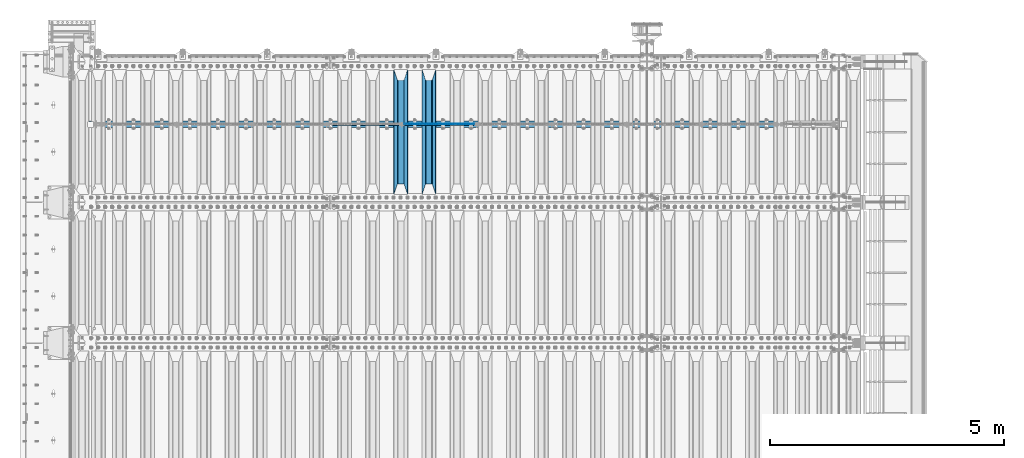
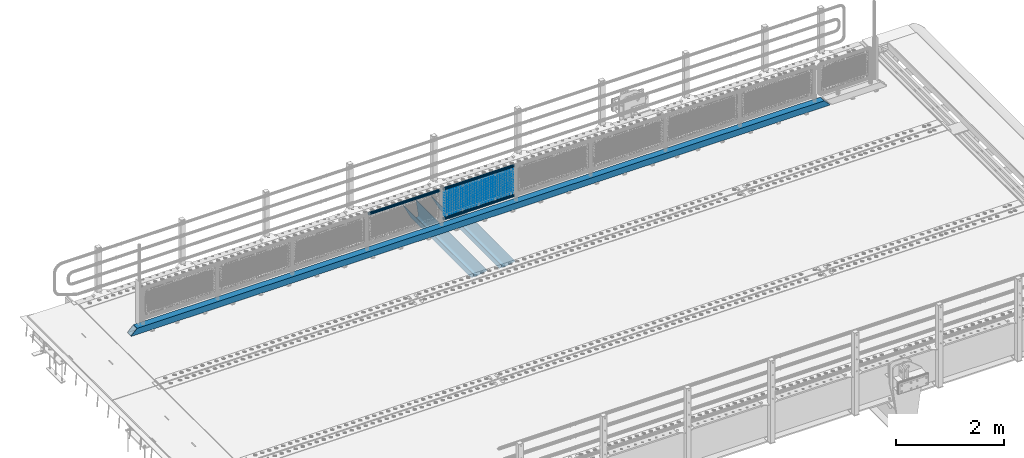
# One storey, part 124 of 247: 23 beams.
"""IFC2X3 building model written with IfcOpenShell, lengths in millimetres."""

from ifc_helpers import new_model, si_unit, frame, origin_with_axes, place, context, subcontext, project, spatial, faceted_brep, material, type_object, element, save


model = new_model("IFC2X3")

# Units and contexts
model_context = context("Model", 3, precision=1e-05, world=origin_with_axes())
body_context = subcontext(model_context, "Body", "Model", "MODEL_VIEW")
ifc_project = project(units=[si_unit("LENGTHUNIT", "METRE", prefix="MILLI"), si_unit("AREAUNIT", "SQUARE_METRE"), si_unit("VOLUMEUNIT", "CUBIC_METRE"), si_unit("MASSUNIT", "GRAM", prefix="KILO"), si_unit("TIMEUNIT", "SECOND"), si_unit("PLANEANGLEUNIT", "RADIAN"), si_unit("SOLIDANGLEUNIT", "STERADIAN"), si_unit("THERMODYNAMICTEMPERATUREUNIT", "DEGREE_CELSIUS"), si_unit("LUMINOUSINTENSITYUNIT", "LUMEN")], contexts=[model_context])

# Site, building, storey
site_placement = place(None, origin_with_axes())
site = spatial("IfcSite", under=ifc_project, at=site_placement, CompositionType="ELEMENT")
building_placement = place(site_placement, origin_with_axes())
building = spatial("IfcBuilding", under=site, at=building_placement, Name="Standard", CompositionType="ELEMENT")
storey_placement = place(building_placement, origin_with_axes())
storey = spatial("IfcBuildingStorey", under=building, at=storey_placement, Name="Undefined", CompositionType="ELEMENT", Elevation=0.0)

# Beams
ifc_material_1 = material(Name="STEEL/S355N")
beam_type_1 = type_object("IfcBeamType", PredefinedType="NOTDEFINED")
beam_1_placement = place(storey_placement, frame((7600.0, 6175.0, -115.0), z_axis=(0.0, 0.0, 1.0), x_axis=(0.0, 1.0, 0.0)))
element("IfcBeam", 1, at=beam_1_placement, inside=storey, type_object=beam_type_1, material=ifc_material_1, context=body_context, shape_type="Brep", body=[
    faceted_brep([(0.0, 150.0, 115.0), (0.0, 143.689999999999, 115.0), (2650.00000000297, 143.689999999999, 115.0), (2650.00000000297, 150.0, 115.0), (2650.00000000297, 142.059565218402, 110.0000000031), (2650.00000000297, 148.369565218403, 110.0000000031), (2441.90079219208, -80.1103600731112, -98.0992078077845), (2437.7588105432, -77.5672621345584, -102.241189456673), (2434.06523489746, -74.4080125315522, -105.934765102404), (2430.91086095089, -70.710272125576, -109.089139048974), (2428.37322971128, -66.5649389910068, -111.626770288588), (2426.51472138054, -62.0739139532889, -113.485278619323), (2425.38102192091, -57.3475956567672, -114.618978078955), (2424.99999999987, -52.5021667386536, -115.0), (2424.99999999987, 52.5021667386536, -115.0), (2425.38102192091, 57.3475956567672, -114.618978078955), (2426.51472138054, 62.0739139532889, -113.485278619323), (2428.37322971128, 66.5649389910068, -111.626770288588), (2430.91086095089, 70.710272125576, -109.089139048974), (2434.06523489746, 74.4080125315522, -105.934765102404), (2437.7588105432, 77.5672621345584, -102.241189456673), (2441.90079219208, 80.1103600731112, -98.0992078077846), (2446.38936140511, 81.9747917625791, -93.6106385947584), (2448.24948500409, 76.2713538057251, -91.7505149957729), (2444.62967112262, 74.76777986261, -95.3703288772456), (2441.28936334126, 72.7168944282894, -98.710636658607), (2438.31067330438, 70.1691124903846, -101.689326695487), (2435.76682334747, 67.1870637758839, -104.233176652398), (2433.72034654133, 63.8440531834895, -106.279653458539), (2432.22154950041, 60.222258798236, -107.778450499454), (2431.30727574265, 56.4107117849089, -108.692724257221), (2430.99999999987, 52.5031078186876, -109.0), (2430.99999999987, -52.5031078186876, -109.0), (2431.30727574265, -56.4107117849089, -108.692724257221), (2432.22154950041, -60.222258798236, -107.778450499454), (2433.72034654133, -63.8440531834895, -106.279653458539), (2435.76682334747, -67.1870637758839, -104.233176652398), (2438.31067330438, -70.1691124903846, -101.689326695487), (2441.28936334126, -72.7168944282894, -98.7106366586071), (2444.62967112262, -74.76777986261, -95.3703288772457), (2448.24948500409, -76.2713538057251, -91.7505149957729), (2650.00000000297, -142.059565218402, 110.0000000031), (2650.00000000297, -148.369565218403, 110.0000000031), (2446.38936140511, -81.9747917625791, -93.6106385947584), (2650.00000000297, -143.689999999999, 115.0), (2650.00000000297, -150.0, 115.0), (0.0, -143.689999999999, 115.0), (0.0, -150.0, 115.0), (0.0, -148.369565218261, 110.000000002663), (203.610638597422, -81.9747917625791, -93.6106385947584), (208.099207810448, -80.1103600731112, -98.0992078077845), (212.241189459336, -77.5672621345584, -102.241189456673), (215.934765105068, -74.4080125315522, -105.934765102404), (219.089139051637, -70.710272125576, -109.089139048974), (221.626770291251, -66.5649389910068, -111.626770288588), (223.485278621985, -62.0739139532889, -113.485278619323), (224.618978081617, -57.3475956567672, -114.618978078955), (225.000000002663, -52.5021667386536, -115.0), (225.000000002663, 52.5021667386536, -115.0), (224.618978081617, 57.3475956567672, -114.618978078955), (223.485278621985, 62.0739139532889, -113.485278619323), (221.626770291251, 66.5649389910068, -111.626770288588), (219.089139051637, 70.710272125576, -109.089139048974), (215.934765105068, 74.4080125315522, -105.934765102404), (212.241189459336, 77.5672621345584, -102.241189456673), (208.099207810448, 80.1103600731112, -98.0992078077846), (203.610638597422, 81.9747917625791, -93.6106385947584), (0.0, 148.369565218261, 110.000000002663), (0.0, 142.05956521826, 110.000000002663), (201.750514998436, 76.2713538057251, -91.7505149957729), (205.370328879908, 74.76777986261, -95.3703288772456), (208.710636661271, 72.7168944282894, -98.710636658607), (211.68932669815, 70.1691124903846, -101.689326695487), (214.233176655061, 67.1870637758839, -104.233176652398), (216.279653461202, 63.8440531834895, -106.279653458539), (217.778450502117, 60.222258798236, -107.778450499454), (218.692724259885, 56.4107117849089, -108.692724257221), (219.000000002663, 52.5031078186876, -109.0), (219.000000002663, -52.5031078186876, -109.0), (218.692724259885, -56.4107117849089, -108.692724257221), (217.778450502117, -60.222258798236, -107.778450499454), (216.279653461202, -63.8440531834895, -106.279653458539), (214.233176655061, -67.1870637758839, -104.233176652398), (211.68932669815, -70.1691124903846, -101.689326695487), (208.710636661271, -72.7168944282894, -98.7106366586071), (205.370328879908, -74.76777986261, -95.3703288772457), (201.750514998436, -76.2713538057251, -91.7505149957729), (0.0, -142.05956521826, 110.000000002663)], [[[0, 1, 2, 3]], [[3, 2, 4, 5]], [[6, 7, 8, 9, 10, 11, 12, 13, 14, 15, 16, 17, 18, 19, 20, 21, 22, 5, 4, 23, 24, 25, 26, 27, 28, 29, 30, 31, 32, 33, 34, 35, 36, 37, 38, 39, 40, 41, 42, 43]], [[44, 45, 42, 41]], [[46, 47, 45, 44]], [[43, 42, 45, 47, 48, 49]], [[6, 43, 49, 50]], [[7, 6, 50, 51]], [[8, 7, 51, 52]], [[9, 8, 52, 53]], [[10, 9, 53, 54]], [[11, 10, 54, 55]], [[12, 11, 55, 56]], [[13, 12, 56, 57]], [[14, 13, 57, 58]], [[15, 14, 58, 59]], [[16, 15, 59, 60]], [[17, 16, 60, 61]], [[18, 17, 61, 62]], [[19, 18, 62, 63]], [[20, 19, 63, 64]], [[21, 20, 64, 65]], [[22, 21, 65, 66]], [[0, 3, 5, 22, 66, 67]], [[1, 0, 67, 68]], [[23, 4, 2, 1, 68, 69]], [[24, 23, 69, 70]], [[25, 24, 70, 71]], [[26, 25, 71, 72]], [[27, 26, 72, 73]], [[28, 27, 73, 74]], [[29, 28, 74, 75]], [[30, 29, 75, 76]], [[31, 30, 76, 77]], [[32, 31, 77, 78]], [[33, 32, 78, 79]], [[34, 33, 79, 80]], [[35, 34, 80, 81]], [[36, 35, 81, 82]], [[37, 36, 82, 83]], [[38, 37, 83, 84]], [[39, 38, 84, 85]], [[40, 39, 85, 86]], [[46, 44, 41, 40, 86, 87]], [[47, 46, 87, 48]], [[86, 85, 84, 83, 82, 81, 80, 79, 78, 77, 76, 75, 74, 73, 72, 71, 70, 69, 68, 67, 66, 65, 64, 63, 62, 61, 60, 59, 58, 57, 56, 55, 54, 53, 52, 51, 50, 49, 48, 87]]]),
])
beam_2_placement = place(storey_placement, frame((7000.0, 6175.0, -115.0), z_axis=(0.0, 0.0, 1.0), x_axis=(0.0, 1.0, 0.0)))
element("IfcBeam", 2, at=beam_2_placement, inside=storey, type_object=beam_type_1, material=ifc_material_1, context=body_context, shape_type="Brep", body=[
    faceted_brep([(0.0, 150.0, 115.0), (0.0, 143.689999999999, 115.0), (2650.00000000297, 143.689999999999, 115.0), (2650.00000000297, 150.0, 115.0), (2650.00000000297, 142.059565218402, 110.0000000031), (2650.00000000297, 148.369565218403, 110.0000000031), (2441.90079219208, -80.1103600731112, -98.0992078077845), (2437.7588105432, -77.5672621345584, -102.241189456673), (2434.06523489746, -74.4080125315522, -105.934765102404), (2430.91086095089, -70.710272125576, -109.089139048974), (2428.37322971128, -66.5649389910068, -111.626770288588), (2426.51472138054, -62.0739139532889, -113.485278619323), (2425.38102192091, -57.3475956567672, -114.618978078955), (2424.99999999987, -52.5021667386536, -115.0), (2424.99999999987, 52.5021667386536, -115.0), (2425.38102192091, 57.3475956567672, -114.618978078955), (2426.51472138054, 62.0739139532889, -113.485278619323), (2428.37322971128, 66.5649389910068, -111.626770288588), (2430.91086095089, 70.710272125576, -109.089139048974), (2434.06523489746, 74.4080125315522, -105.934765102404), (2437.7588105432, 77.5672621345584, -102.241189456673), (2441.90079219208, 80.1103600731112, -98.0992078077846), (2446.38936140511, 81.9747917625791, -93.6106385947584), (2448.24948500409, 76.2713538057251, -91.7505149957729), (2444.62967112262, 74.76777986261, -95.3703288772456), (2441.28936334126, 72.7168944282894, -98.710636658607), (2438.31067330438, 70.1691124903846, -101.689326695487), (2435.76682334747, 67.1870637758839, -104.233176652398), (2433.72034654133, 63.8440531834895, -106.279653458539), (2432.22154950041, 60.222258798236, -107.778450499454), (2431.30727574265, 56.4107117849089, -108.692724257221), (2430.99999999987, 52.5031078186876, -109.0), (2430.99999999987, -52.5031078186876, -109.0), (2431.30727574265, -56.4107117849089, -108.692724257221), (2432.22154950041, -60.222258798236, -107.778450499454), (2433.72034654133, -63.8440531834895, -106.279653458539), (2435.76682334747, -67.1870637758839, -104.233176652398), (2438.31067330438, -70.1691124903846, -101.689326695487), (2441.28936334126, -72.7168944282894, -98.7106366586071), (2444.62967112262, -74.76777986261, -95.3703288772457), (2448.24948500409, -76.2713538057251, -91.7505149957729), (2650.00000000297, -142.059565218402, 110.0000000031), (2650.00000000297, -148.369565218403, 110.0000000031), (2446.38936140511, -81.9747917625791, -93.6106385947584), (2650.00000000297, -143.689999999999, 115.0), (2650.00000000297, -150.0, 115.0), (0.0, -143.689999999999, 115.0), (0.0, -150.0, 115.0), (0.0, -148.369565218261, 110.000000002663), (203.610638597422, -81.9747917625791, -93.6106385947584), (208.099207810448, -80.1103600731112, -98.0992078077845), (212.241189459336, -77.5672621345584, -102.241189456673), (215.934765105068, -74.4080125315522, -105.934765102404), (219.089139051637, -70.710272125576, -109.089139048974), (221.626770291251, -66.5649389910068, -111.626770288588), (223.485278621985, -62.0739139532889, -113.485278619323), (224.618978081617, -57.3475956567672, -114.618978078955), (225.000000002663, -52.5021667386536, -115.0), (225.000000002663, 52.5021667386536, -115.0), (224.618978081617, 57.3475956567672, -114.618978078955), (223.485278621985, 62.0739139532889, -113.485278619323), (221.626770291251, 66.5649389910068, -111.626770288588), (219.089139051637, 70.710272125576, -109.089139048974), (215.934765105068, 74.4080125315522, -105.934765102404), (212.241189459336, 77.5672621345584, -102.241189456673), (208.099207810448, 80.1103600731112, -98.0992078077846), (203.610638597422, 81.9747917625791, -93.6106385947584), (0.0, 148.369565218261, 110.000000002663), (0.0, 142.05956521826, 110.000000002663), (201.750514998436, 76.2713538057251, -91.7505149957729), (205.370328879908, 74.76777986261, -95.3703288772456), (208.710636661271, 72.7168944282894, -98.710636658607), (211.68932669815, 70.1691124903846, -101.689326695487), (214.233176655061, 67.1870637758839, -104.233176652398), (216.279653461202, 63.8440531834895, -106.279653458539), (217.778450502117, 60.222258798236, -107.778450499454), (218.692724259885, 56.4107117849089, -108.692724257221), (219.000000002663, 52.5031078186876, -109.0), (219.000000002663, -52.5031078186876, -109.0), (218.692724259885, -56.4107117849089, -108.692724257221), (217.778450502117, -60.222258798236, -107.778450499454), (216.279653461202, -63.8440531834895, -106.279653458539), (214.233176655061, -67.1870637758839, -104.233176652398), (211.68932669815, -70.1691124903846, -101.689326695487), (208.710636661271, -72.7168944282894, -98.7106366586071), (205.370328879908, -74.76777986261, -95.3703288772457), (201.750514998436, -76.2713538057251, -91.7505149957729), (0.0, -142.05956521826, 110.000000002663)], [[[0, 1, 2, 3]], [[3, 2, 4, 5]], [[6, 7, 8, 9, 10, 11, 12, 13, 14, 15, 16, 17, 18, 19, 20, 21, 22, 5, 4, 23, 24, 25, 26, 27, 28, 29, 30, 31, 32, 33, 34, 35, 36, 37, 38, 39, 40, 41, 42, 43]], [[44, 45, 42, 41]], [[46, 47, 45, 44]], [[43, 42, 45, 47, 48, 49]], [[6, 43, 49, 50]], [[7, 6, 50, 51]], [[8, 7, 51, 52]], [[9, 8, 52, 53]], [[10, 9, 53, 54]], [[11, 10, 54, 55]], [[12, 11, 55, 56]], [[13, 12, 56, 57]], [[14, 13, 57, 58]], [[15, 14, 58, 59]], [[16, 15, 59, 60]], [[17, 16, 60, 61]], [[18, 17, 61, 62]], [[19, 18, 62, 63]], [[20, 19, 63, 64]], [[21, 20, 64, 65]], [[22, 21, 65, 66]], [[0, 3, 5, 22, 66, 67]], [[1, 0, 67, 68]], [[23, 4, 2, 1, 68, 69]], [[24, 23, 69, 70]], [[25, 24, 70, 71]], [[26, 25, 71, 72]], [[27, 26, 72, 73]], [[28, 27, 73, 74]], [[29, 28, 74, 75]], [[30, 29, 75, 76]], [[31, 30, 76, 77]], [[32, 31, 77, 78]], [[33, 32, 78, 79]], [[34, 33, 79, 80]], [[35, 34, 80, 81]], [[36, 35, 81, 82]], [[37, 36, 82, 83]], [[38, 37, 83, 84]], [[39, 38, 84, 85]], [[40, 39, 85, 86]], [[46, 44, 41, 40, 86, 87]], [[47, 46, 87, 48]], [[86, 85, 84, 83, 82, 81, 80, 79, 78, 77, 76, 75, 74, 73, 72, 71, 70, 69, 68, 67, 66, 65, 64, 63, 62, 61, 60, 59, 58, 57, 56, 55, 54, 53, 52, 51, 50, 49, 48, 87]]]),
])
ifc_material_2 = material()
beam_type_2 = type_object("IfcBeamType", PredefinedType="NOTDEFINED")
beam_3_placement = place(storey_placement, frame((325.0, 7664.5, 98.0199999999977), z_axis=(0.0, 0.0, 1.0), x_axis=(1.0, 0.0, 0.0)))
element("IfcBeam", 3, at=beam_3_placement, inside=storey, type_object=beam_type_2, material=ifc_material_2, context=body_context, shape_type="Brep", body=[
    faceted_brep([(0.0, -70.0, -70.0), (0.0, 70.0, -70.0), (14992.0, 70.0, -70.0), (14992.0, -70.0, -70.0), (14861.8884698478, -70.0, 70.0), (14861.8884698478, 70.0, 70.0), (130.111530936143, 70.0, 70.0), (130.111528976142, -70.0, 70.0), (14992.0, -70.0, -60.0079600980745), (0.0, -70.0, -60.0079591069112), (14871.8964362873, -60.0, 60.0), (14992.0, -60.0, -60.0), (0.0, -60.0, -60.0), (120.103562690862, -60.0, 60.0), (14871.8964362873, 60.0, 60.0), (120.10356437086, 60.0, 60.0), (14992.0, 60.0, -60.0), (0.0, 60.0, -60.0), (14992.0, 70.0, -60.0079600980745), (0.0, 70.0, -60.0079610653511)], [[[0, 1, 2, 3]], [[4, 5, 6, 7]], [[0, 3, 8, 4, 7, 9]], [[10, 11, 12, 13]], [[14, 10, 13, 15]], [[16, 14, 15, 17]], [[4, 8, 11, 10, 14, 16, 18, 5]], [[11, 8, 3, 2, 18, 16]], [[17, 12, 11, 16]], [[1, 0, 9, 12, 17, 19]], [[5, 18, 2, 1, 19, 6]], [[17, 15, 13, 12, 9, 7, 6, 19]]]),
])
beam_type_3 = type_object("IfcBeamType", PredefinedType="NOTDEFINED")
beam_4_placement = place(storey_placement, frame((7055.85000000001, 7664.5, 298.170000000003), z_axis=(0.0, 0.0, 1.0), x_axis=(1.0, 0.0, 0.0)))
element("IfcBeam", 4, at=beam_4_placement, inside=storey, type_object=beam_type_3, material=ifc_material_2, context=body_context, shape_type="Brep", body=[
    faceted_brep([(0.0, -25.3500000000004, 0.0), (0.0, -23.4203461491616, 9.70102501045585), (1530.0, -23.4203461491616, 9.70102501045506), (1530.0, -25.3500000000004, 0.0), (0.0, -17.9251569030794, 17.9251569030785), (1530.0, -17.9251569030794, 17.925156903079), (0.0, -9.70102501045494, 23.4203461491616), (1530.0, -9.70102501045494, 23.4203461491611), (0.0, 0.0, 25.3500000000004), (1530.0, 0.0, 25.35), (0.0, 9.70102501045494, 23.4203461491616), (1530.0, 9.70102501045494, 23.4203461491611), (0.0, 17.9251569030794, 17.9251569030785), (1530.0, 17.9251569030794, 17.925156903079), (0.0, 23.4203461491616, 9.70102501045585), (1530.0, 23.4203461491616, 9.70102501045506), (0.0, 25.3500000000004, 0.0), (1530.0, 25.3500000000004, 0.0), (0.0, 23.4203461491616, -9.70102501045585), (1530.0, 23.4203461491616, -9.70102501045506), (0.0, 17.9251569030794, -17.9251569030785), (1530.0, 17.9251569030794, -17.925156903079), (0.0, 9.70102501045494, -23.4203461491616), (1530.0, 9.70102501045494, -23.4203461491611), (0.0, 0.0, -25.3500000000004), (1530.0, 0.0, -25.35), (0.0, -9.70102501045494, -23.4203461491616), (1530.0, -9.70102501045494, -23.4203461491611), (0.0, -17.9251569030794, -17.9251569030785), (1530.0, -17.9251569030794, -17.925156903079), (0.0, -23.4203461491616, -9.70102501045585), (1530.0, -23.4203461491616, -9.70102501045506), (0.0, -30.1499999999996, 0.0), (0.0, -27.8549679052148, -11.5379054858076), (1530.0, -27.8549679052148, -11.5379054858075), (1530.0, -30.1499999999996, 0.0), (0.0, -21.3192694527743, -21.3192694527752), (1530.0, -21.3192694527743, -21.3192694527744), (0.0, -11.5379054858076, -27.8549679052157), (1530.0, -11.5379054858076, -27.8549679052153), (0.0, 0.0, -30.1499999999996), (1530.0, 0.0, -30.15), (0.0, 11.5379054858076, -27.8549679052157), (1530.0, 11.5379054858076, -27.8549679052153), (0.0, 21.3192694527743, -21.3192694527752), (1530.0, 21.3192694527743, -21.3192694527744), (0.0, 27.8549679052157, -11.5379054858076), (1530.0, 27.8549679052157, -11.5379054858074), (0.0, 30.1499999999996, 0.0), (1530.0, 30.1499999999996, 0.0), (0.0, 27.8549679052157, 11.5379054858076), (1530.0, 27.8549679052157, 11.5379054858074), (0.0, 21.3192694527743, 21.3192694527752), (1530.0, 21.3192694527743, 21.3192694527744), (0.0, 11.5379054858076, 27.8549679052157), (1530.0, 11.5379054858076, 27.8549679052153), (0.0, 0.0, 30.1499999999996), (1530.0, 0.0, 30.15), (0.0, -11.5379054858076, 27.8549679052157), (1530.0, -11.5379054858076, 27.8549679052153), (0.0, -21.3192694527743, 21.3192694527752), (1530.0, -21.3192694527743, 21.3192694527744), (0.0, -27.8549679052157, 11.5379054858076), (1530.0, -27.8549679052157, 11.5379054858074)], [[[0, 1, 2, 3]], [[1, 4, 5, 2]], [[4, 6, 7, 5]], [[6, 8, 9, 7]], [[8, 10, 11, 9]], [[10, 12, 13, 11]], [[12, 14, 15, 13]], [[14, 16, 17, 15]], [[16, 18, 19, 17]], [[18, 20, 21, 19]], [[20, 22, 23, 21]], [[22, 24, 25, 23]], [[24, 26, 27, 25]], [[26, 28, 29, 27]], [[28, 30, 31, 29]], [[30, 0, 3, 31]], [[32, 33, 34, 35]], [[33, 36, 37, 34]], [[36, 38, 39, 37]], [[38, 40, 41, 39]], [[40, 42, 43, 41]], [[42, 44, 45, 43]], [[44, 46, 47, 45]], [[46, 48, 49, 47]], [[48, 50, 51, 49]], [[50, 52, 53, 51]], [[52, 54, 55, 53]], [[54, 56, 57, 55]], [[56, 58, 59, 57]], [[58, 60, 61, 59]], [[60, 62, 63, 61]], [[62, 32, 35, 63]], [[37, 39, 41, 43, 45, 47, 49, 51, 53, 55, 57, 59, 61, 63, 35, 34], [5, 7, 9, 11, 13, 15, 17, 19, 21, 23, 25, 27, 29, 31, 3, 2]], [[62, 60, 58, 56, 54, 52, 50, 48, 46, 44, 42, 40, 38, 36, 33, 32], [30, 28, 26, 24, 22, 20, 18, 16, 14, 12, 10, 8, 6, 4, 1, 0]]]),
])
beam_5_placement = place(storey_placement, frame((7055.85, 7664.5, 969.850000000002), z_axis=(0.0, 0.0, 1.0), x_axis=(1.0, 0.0, 0.0)))
element("IfcBeam", 5, at=beam_5_placement, inside=storey, type_object=beam_type_3, material=ifc_material_2, context=body_context, shape_type="Brep", body=[
    faceted_brep([(0.0, -25.3500000000004, 0.0), (0.0, -23.4203461491616, 9.70102501045585), (1530.0, -23.4203461491616, 9.70102501045506), (1530.0, -25.3500000000004, 0.0), (0.0, -17.9251569030794, 17.9251569030785), (1530.0, -17.9251569030794, 17.925156903079), (0.0, -9.70102501045494, 23.4203461491616), (1530.0, -9.70102501045494, 23.4203461491611), (0.0, 0.0, 25.3500000000004), (1530.0, 0.0, 25.35), (0.0, 9.70102501045494, 23.4203461491616), (1530.0, 9.70102501045494, 23.4203461491611), (0.0, 17.9251569030794, 17.9251569030785), (1530.0, 17.9251569030794, 17.925156903079), (0.0, 23.4203461491616, 9.70102501045585), (1530.0, 23.4203461491616, 9.70102501045506), (0.0, 25.3500000000004, 0.0), (1530.0, 25.3500000000004, 0.0), (0.0, 23.4203461491616, -9.70102501045585), (1530.0, 23.4203461491616, -9.70102501045506), (0.0, 17.9251569030794, -17.9251569030785), (1530.0, 17.9251569030794, -17.925156903079), (0.0, 9.70102501045494, -23.4203461491616), (1530.0, 9.70102501045494, -23.4203461491611), (0.0, 0.0, -25.3500000000004), (1530.0, 0.0, -25.35), (0.0, -9.70102501045494, -23.4203461491616), (1530.0, -9.70102501045494, -23.4203461491611), (0.0, -17.9251569030794, -17.9251569030785), (1530.0, -17.9251569030794, -17.925156903079), (0.0, -23.4203461491616, -9.70102501045585), (1530.0, -23.4203461491616, -9.70102501045506), (0.0, -30.1499999999996, 0.0), (0.0, -27.8549679052148, -11.5379054858076), (1530.0, -27.8549679052148, -11.5379054858075), (1530.0, -30.1499999999996, 0.0), (0.0, -21.3192694527743, -21.3192694527752), (1530.0, -21.3192694527743, -21.3192694527744), (0.0, -11.5379054858076, -27.8549679052157), (1530.0, -11.5379054858076, -27.8549679052153), (0.0, 0.0, -30.1499999999996), (1530.0, 0.0, -30.15), (0.0, 11.5379054858076, -27.8549679052157), (1530.0, 11.5379054858076, -27.8549679052153), (0.0, 21.3192694527743, -21.3192694527752), (1530.0, 21.3192694527743, -21.3192694527744), (0.0, 27.8549679052157, -11.5379054858076), (1530.0, 27.8549679052157, -11.5379054858074), (0.0, 30.1499999999996, 0.0), (1530.0, 30.1499999999996, 0.0), (0.0, 27.8549679052157, 11.5379054858076), (1530.0, 27.8549679052157, 11.5379054858074), (0.0, 21.3192694527743, 21.3192694527752), (1530.0, 21.3192694527743, 21.3192694527744), (0.0, 11.5379054858076, 27.8549679052157), (1530.0, 11.5379054858076, 27.8549679052153), (0.0, 0.0, 30.1499999999996), (1530.0, 0.0, 30.15), (0.0, -11.5379054858076, 27.8549679052157), (1530.0, -11.5379054858076, 27.8549679052153), (0.0, -21.3192694527743, 21.3192694527752), (1530.0, -21.3192694527743, 21.3192694527744), (0.0, -27.8549679052157, 11.5379054858076), (1530.0, -27.8549679052157, 11.5379054858074)], [[[0, 1, 2, 3]], [[1, 4, 5, 2]], [[4, 6, 7, 5]], [[6, 8, 9, 7]], [[8, 10, 11, 9]], [[10, 12, 13, 11]], [[12, 14, 15, 13]], [[14, 16, 17, 15]], [[16, 18, 19, 17]], [[18, 20, 21, 19]], [[20, 22, 23, 21]], [[22, 24, 25, 23]], [[24, 26, 27, 25]], [[26, 28, 29, 27]], [[28, 30, 31, 29]], [[30, 0, 3, 31]], [[32, 33, 34, 35]], [[33, 36, 37, 34]], [[36, 38, 39, 37]], [[38, 40, 41, 39]], [[40, 42, 43, 41]], [[42, 44, 45, 43]], [[44, 46, 47, 45]], [[46, 48, 49, 47]], [[48, 50, 51, 49]], [[50, 52, 53, 51]], [[52, 54, 55, 53]], [[54, 56, 57, 55]], [[56, 58, 59, 57]], [[58, 60, 61, 59]], [[60, 62, 63, 61]], [[62, 32, 35, 63]], [[37, 39, 41, 43, 45, 47, 49, 51, 53, 55, 57, 59, 61, 63, 35, 34], [5, 7, 9, 11, 13, 15, 17, 19, 21, 23, 25, 27, 29, 31, 3, 2]], [[62, 60, 58, 56, 54, 52, 50, 48, 46, 44, 42, 40, 38, 36, 33, 32], [30, 28, 26, 24, 22, 20, 18, 16, 14, 12, 10, 8, 6, 4, 1, 0]]]),
])
beam_6_placement = place(storey_placement, frame((5455.85, 7664.5, 969.850000000001), z_axis=(0.0, 0.0, 1.0), x_axis=(1.0, 0.0, 0.0)))
element("IfcBeam", 6, at=beam_6_placement, inside=storey, type_object=beam_type_3, material=ifc_material_2, context=body_context, shape_type="Brep", body=[
    faceted_brep([(0.0, -25.3500000000004, 0.0), (0.0, -23.4203461491616, 9.70102501045585), (1530.0, -23.4203461491616, 9.70102501045506), (1530.0, -25.3500000000004, 0.0), (0.0, -17.9251569030794, 17.9251569030785), (1530.0, -17.9251569030794, 17.925156903079), (0.0, -9.70102501045494, 23.4203461491616), (1530.0, -9.70102501045494, 23.4203461491611), (0.0, 0.0, 25.3500000000004), (1530.0, 0.0, 25.35), (0.0, 9.70102501045494, 23.4203461491616), (1530.0, 9.70102501045494, 23.4203461491611), (0.0, 17.9251569030794, 17.9251569030785), (1530.0, 17.9251569030794, 17.925156903079), (0.0, 23.4203461491616, 9.70102501045585), (1530.0, 23.4203461491616, 9.70102501045506), (0.0, 25.3500000000004, 0.0), (1530.0, 25.3500000000004, 0.0), (0.0, 23.4203461491616, -9.70102501045585), (1530.0, 23.4203461491616, -9.70102501045506), (0.0, 17.9251569030794, -17.9251569030785), (1530.0, 17.9251569030794, -17.925156903079), (0.0, 9.70102501045494, -23.4203461491616), (1530.0, 9.70102501045494, -23.4203461491611), (0.0, 0.0, -25.3500000000004), (1530.0, 0.0, -25.35), (0.0, -9.70102501045494, -23.4203461491616), (1530.0, -9.70102501045494, -23.4203461491611), (0.0, -17.9251569030794, -17.9251569030785), (1530.0, -17.9251569030794, -17.925156903079), (0.0, -23.4203461491616, -9.70102501045585), (1530.0, -23.4203461491616, -9.70102501045506), (0.0, -30.1499999999996, 0.0), (0.0, -27.8549679052148, -11.5379054858076), (1530.0, -27.8549679052148, -11.5379054858075), (1530.0, -30.1499999999996, 0.0), (0.0, -21.3192694527743, -21.3192694527752), (1530.0, -21.3192694527743, -21.3192694527744), (0.0, -11.5379054858076, -27.8549679052157), (1530.0, -11.5379054858076, -27.8549679052153), (0.0, 0.0, -30.1499999999996), (1530.0, 0.0, -30.15), (0.0, 11.5379054858076, -27.8549679052157), (1530.0, 11.5379054858076, -27.8549679052153), (0.0, 21.3192694527743, -21.3192694527752), (1530.0, 21.3192694527743, -21.3192694527744), (0.0, 27.8549679052157, -11.5379054858076), (1530.0, 27.8549679052157, -11.5379054858074), (0.0, 30.1499999999996, 0.0), (1530.0, 30.1499999999996, 0.0), (0.0, 27.8549679052157, 11.5379054858076), (1530.0, 27.8549679052157, 11.5379054858074), (0.0, 21.3192694527743, 21.3192694527752), (1530.0, 21.3192694527743, 21.3192694527744), (0.0, 11.5379054858076, 27.8549679052157), (1530.0, 11.5379054858076, 27.8549679052153), (0.0, 0.0, 30.1499999999996), (1530.0, 0.0, 30.15), (0.0, -11.5379054858076, 27.8549679052157), (1530.0, -11.5379054858076, 27.8549679052153), (0.0, -21.3192694527743, 21.3192694527752), (1530.0, -21.3192694527743, 21.3192694527744), (0.0, -27.8549679052157, 11.5379054858076), (1530.0, -27.8549679052157, 11.5379054858074)], [[[0, 1, 2, 3]], [[1, 4, 5, 2]], [[4, 6, 7, 5]], [[6, 8, 9, 7]], [[8, 10, 11, 9]], [[10, 12, 13, 11]], [[12, 14, 15, 13]], [[14, 16, 17, 15]], [[16, 18, 19, 17]], [[18, 20, 21, 19]], [[20, 22, 23, 21]], [[22, 24, 25, 23]], [[24, 26, 27, 25]], [[26, 28, 29, 27]], [[28, 30, 31, 29]], [[30, 0, 3, 31]], [[32, 33, 34, 35]], [[33, 36, 37, 34]], [[36, 38, 39, 37]], [[38, 40, 41, 39]], [[40, 42, 43, 41]], [[42, 44, 45, 43]], [[44, 46, 47, 45]], [[46, 48, 49, 47]], [[48, 50, 51, 49]], [[50, 52, 53, 51]], [[52, 54, 55, 53]], [[54, 56, 57, 55]], [[56, 58, 59, 57]], [[58, 60, 61, 59]], [[60, 62, 63, 61]], [[62, 32, 35, 63]], [[37, 39, 41, 43, 45, 47, 49, 51, 53, 55, 57, 59, 61, 63, 35, 34], [5, 7, 9, 11, 13, 15, 17, 19, 21, 23, 25, 27, 29, 31, 3, 2]], [[62, 60, 58, 56, 54, 52, 50, 48, 46, 44, 42, 40, 38, 36, 33, 32], [30, 28, 26, 24, 22, 20, 18, 16, 14, 12, 10, 8, 6, 4, 1, 0]]]),
])
ifc_material_3 = material(Name="Misc_Undefined")
beam_type_4 = type_object("IfcBeamType", Name="D3", PredefinedType="NOTDEFINED")
for number, where, z_axis, x_axis in (
    (7, (7076.0, 7670.5, 851.597000000002), (0.0, 0.0, 1.0), (1.0, 0.0, 0.0)),
    (8, (7076.0, 7670.5, 669.452000000002), (0.0, 0.0, 1.0), (1.0, 0.0, 0.0)),
    (9, (7076.0, 7670.5, 523.736000000002), (0.0, 0.0, 1.0), (1.0, 0.0, 0.0)),
    (10, (7076.0, 7670.5, 487.307000000002), (0.0, 0.0, 1.0), (1.0, 0.0, 0.0)),
    (11, (7076.0, 7670.5, 705.881000000002), (0.0, 0.0, 1.0), (1.0, 0.0, 0.0)),
    (12, (7076.0, 7670.5, 596.594000000002), (0.0, 0.0, 1.0), (1.0, 0.0, 0.0)),
    (13, (7076.0, 7670.5, 450.878000000002), (0.0, 0.0, 1.0), (1.0, 0.0, 0.0)),
    (14, (7076.0, 7670.5, 815.168000000002), (0.0, 0.0, 1.0), (1.0, 0.0, 0.0)),
    (15, (7076.0, 7670.5, 888.026000000002), (0.0, 0.0, 1.0), (1.0, 0.0, 0.0)),
    (16, (7076.0, 7670.5, 778.739000000002), (0.0, 0.0, 1.0), (1.0, 0.0, 0.0)),
    (17, (7076.0, 7670.5, 742.310000000002), (0.0, 0.0, 1.0), (1.0, 0.0, 0.0)),
    (18, (7076.0, 7670.5, 633.023000000002), (0.0, 0.0, 1.0), (1.0, 0.0, 0.0)),
    (19, (7076.0, 7670.5, 560.165000000002), (0.0, 0.0, 1.0), (1.0, 0.0, 0.0)),
    (20, (7076.0, 7670.5, 414.449000000002), (0.0, 0.0, 1.0), (1.0, 0.0, 0.0)),
):
    element("IfcBeam", number, at=place(storey_placement, frame(where, z_axis=z_axis, x_axis=x_axis)), inside=storey, type_object=beam_type_4, material=ifc_material_3, ObjectType="D3", context=body_context, shape_type="Brep", body=[
        faceted_brep([(1.81898940354586e-12, -1.5, -5.6843418860808e-14), (0.0, -0.75, -1.29903810567703), (1490.0, -0.75, -1.29903810567669), (1490.0, -1.5, 0.0), (0.0, 0.75, -1.29903810567703), (1490.0, 0.75, -1.29903810567669), (1.81898940354586e-12, 1.5, -5.6843418860808e-14), (1490.0, 1.5, 0.0), (0.0, 0.75, 1.29903810567703), (1490.0, 0.75, 1.29903810567669), (0.0, -0.75, 1.29903810567703), (1490.0, -0.75, 1.29903810567669)], [[[0, 1, 2, 3]], [[1, 4, 5, 2]], [[4, 6, 7, 5]], [[6, 8, 9, 7]], [[8, 10, 11, 9]], [[10, 0, 3, 11]], [[5, 7, 9, 11, 3, 2]], [[10, 8, 6, 4, 1, 0]]]),
    ])
beam_7_placement = place(storey_placement, frame((7101.0, 7670.5, 353.020000000002), z_axis=(0.0, 0.0, 1.0), x_axis=(1.0, 0.0, 0.0)))
element("IfcBeam", 21, at=beam_7_placement, inside=storey, type_object=beam_type_4, material=ifc_material_3, ObjectType="D3", context=body_context, shape_type="Brep", body=[
    faceted_brep([(1.81898940354586e-12, -1.5, -5.6843418860808e-14), (0.0, -0.75, -1.29903810567703), (1440.0, -0.75, -1.29903810567669), (1440.0, -1.5, 0.0), (0.0, 0.75, -1.29903810567703), (1440.0, 0.75, -1.29903810567663), (1.81898940354586e-12, 1.5, -5.6843418860808e-14), (1440.0, 1.5, 0.0), (0.0, 0.75, 1.29903810567703), (1440.0, 0.75, 1.29903810567669), (0.0, -0.75, 1.29903810567703), (1440.0, -0.75, 1.29903810567669)], [[[0, 1, 2, 3]], [[1, 4, 5, 2]], [[4, 6, 7, 5]], [[6, 8, 9, 7]], [[8, 10, 11, 9]], [[10, 0, 3, 11]], [[5, 7, 9, 11, 3, 2]], [[10, 8, 6, 4, 1, 0]]]),
])
beam_8_placement = place(storey_placement, frame((7076.0, 7670.5, 378.020000000002), z_axis=(0.0, 0.0, 1.0), x_axis=(1.0, 0.0, 0.0)))
element("IfcBeam", 22, at=beam_8_placement, inside=storey, type_object=beam_type_4, material=ifc_material_3, ObjectType="D3", context=body_context, shape_type="Brep", body=[
    faceted_brep([(1.81898940354586e-12, -1.5, -5.6843418860808e-14), (0.0, -0.75, -1.29903810567703), (1490.0, -0.75, -1.29903810567669), (1490.0, -1.5, 0.0), (0.0, 0.75, -1.29903810567703), (1490.0, 0.75, -1.29903810567669), (1.81898940354586e-12, 1.5, -5.6843418860808e-14), (1490.0, 1.5, 0.0), (0.0, 0.75, 1.29903810567703), (1490.0, 0.75, 1.29903810567669), (0.0, -0.75, 1.29903810567703), (1490.0, -0.75, 1.29903810567669)], [[[0, 1, 2, 3]], [[1, 4, 5, 2]], [[4, 6, 7, 5]], [[6, 8, 9, 7]], [[8, 10, 11, 9]], [[10, 0, 3, 11]], [[5, 7, 9, 11, 3, 2]], [[10, 8, 6, 4, 1, 0]]]),
])
beam_9_placement = place(storey_placement, frame((7101.0, 7670.5, 913.020000000002), z_axis=(0.0, 0.0, 1.0), x_axis=(1.0, 0.0, 0.0)))
element("IfcBeam", 23, at=beam_9_placement, inside=storey, type_object=beam_type_4, material=ifc_material_3, ObjectType="D3", context=body_context, shape_type="Brep", body=[
    faceted_brep([(1.81898940354586e-12, -1.5, -5.6843418860808e-14), (0.0, -0.75, -1.29903810567703), (1440.0, -0.75, -1.29903810567669), (1440.0, -1.5, 0.0), (0.0, 0.75, -1.29903810567703), (1440.0, 0.75, -1.29903810567663), (1.81898940354586e-12, 1.5, -5.6843418860808e-14), (1440.0, 1.5, 0.0), (0.0, 0.75, 1.29903810567703), (1440.0, 0.75, 1.29903810567669), (0.0, -0.75, 1.29903810567703), (1440.0, -0.75, 1.29903810567669)], [[[0, 1, 2, 3]], [[1, 4, 5, 2]], [[4, 6, 7, 5]], [[6, 8, 9, 7]], [[8, 10, 11, 9]], [[10, 0, 3, 11]], [[5, 7, 9, 11, 3, 2]], [[10, 8, 6, 4, 1, 0]]]),
])

save(model, "model.ifc")
